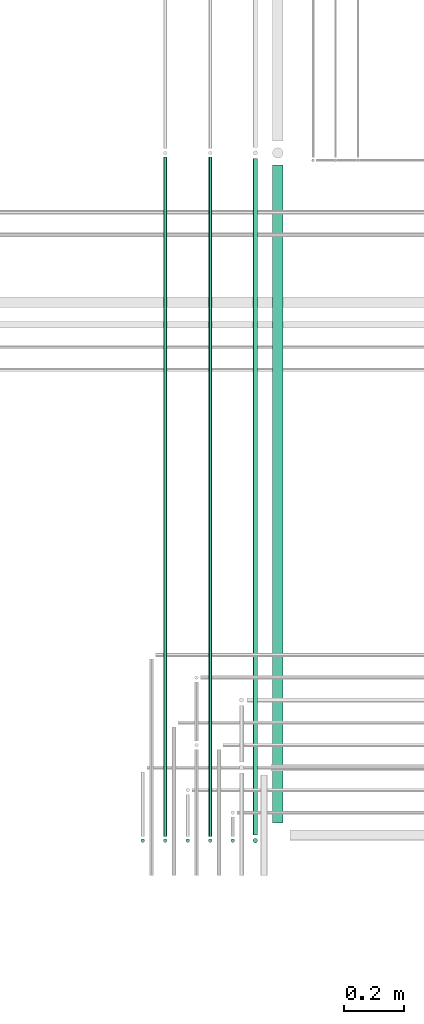
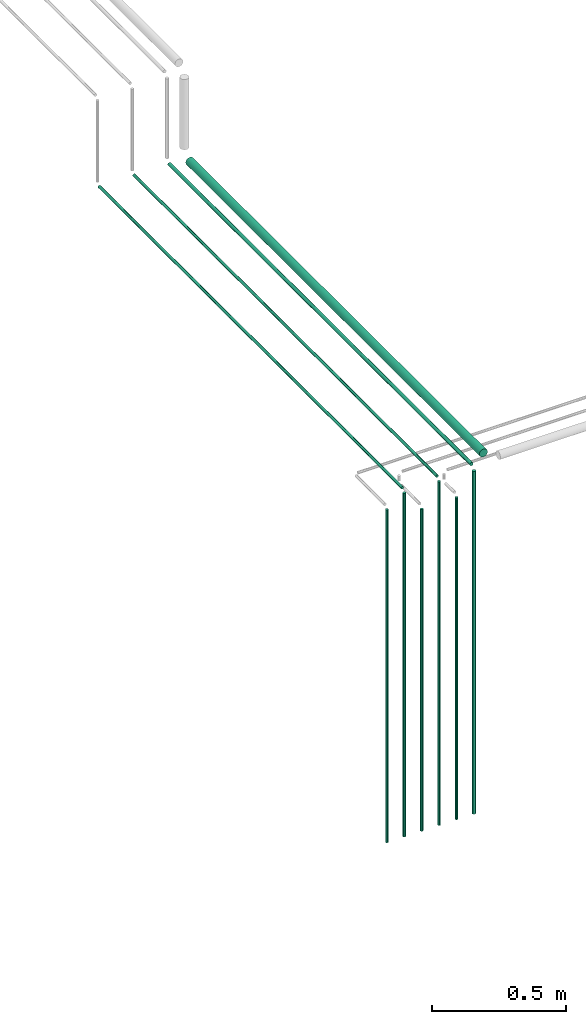
# One storey, part 109 of 331: 10 flow segments.
"""IFC2X3 building model written with IfcOpenShell, lengths in millimetres."""

from ifc_helpers import new_model, entity, si_unit, converted_unit, derived_unit, direction, frame, frame_2d, origin, origin_2d_with_axis, place, context, subcontext, project, spatial, circle, extrude, type_object, element, save


model = new_model("IFC2X3")

# Units and contexts
model_context = context("Model", 3, precision=0.01, world=origin(), true_north=direction((6.12303176911189e-17, 1.0)))
body_context = subcontext(model_context, "Body", "Model", "MODEL_VIEW")
ifc_project = project(units=[si_unit("LENGTHUNIT", "METRE", prefix="MILLI"), si_unit("AREAUNIT", "SQUARE_METRE"), si_unit("VOLUMEUNIT", "CUBIC_METRE"), converted_unit("PLANEANGLEUNIT", "DEGREE", entity("IfcRatioMeasure", 0.0174532925199433), si_unit("PLANEANGLEUNIT", "RADIAN"), dimensions=[0, 0, 0, 0, 0, 0, 0]), si_unit("MASSUNIT", "GRAM", prefix="KILO"), derived_unit("MASSDENSITYUNIT", [(si_unit("MASSUNIT", "GRAM", prefix="KILO"), 1), (si_unit("LENGTHUNIT", "METRE"), -3)]), derived_unit("MOMENTOFINERTIAUNIT", [(si_unit("LENGTHUNIT", "METRE"), 4)]), si_unit("TIMEUNIT", "SECOND"), si_unit("FREQUENCYUNIT", "HERTZ"), si_unit("THERMODYNAMICTEMPERATUREUNIT", "DEGREE_CELSIUS"), derived_unit("THERMALTRANSMITTANCEUNIT", [(si_unit("MASSUNIT", "GRAM", prefix="KILO"), 1), (si_unit("THERMODYNAMICTEMPERATUREUNIT", "KELVIN"), -1), (si_unit("TIMEUNIT", "SECOND"), -3)]), derived_unit("VOLUMETRICFLOWRATEUNIT", [(si_unit("LENGTHUNIT", "METRE"), 3), (si_unit("TIMEUNIT", "SECOND"), -1)]), derived_unit("MASSFLOWRATEUNIT", [(si_unit("MASSUNIT", "GRAM", prefix="KILO"), 1), (si_unit("TIMEUNIT", "SECOND"), -1)]), derived_unit("ROTATIONALFREQUENCYUNIT", [(si_unit("TIMEUNIT", "SECOND"), -1)]), si_unit("ELECTRICCURRENTUNIT", "AMPERE"), si_unit("ELECTRICVOLTAGEUNIT", "VOLT"), si_unit("POWERUNIT", "WATT"), si_unit("FORCEUNIT", "NEWTON", prefix="KILO"), si_unit("ILLUMINANCEUNIT", "LUX"), si_unit("LUMINOUSFLUXUNIT", "LUMEN"), si_unit("LUMINOUSINTENSITYUNIT", "CANDELA"), derived_unit("USERDEFINED", [(si_unit("MASSUNIT", "GRAM", prefix="KILO"), -1), (si_unit("LENGTHUNIT", "METRE"), -2), (si_unit("TIMEUNIT", "SECOND"), 3), (si_unit("LUMINOUSFLUXUNIT", "LUMEN"), 1)]), derived_unit("LINEARVELOCITYUNIT", [(si_unit("LENGTHUNIT", "METRE"), 1), (si_unit("TIMEUNIT", "SECOND"), -1)]), si_unit("PRESSUREUNIT", "PASCAL"), derived_unit("USERDEFINED", [(si_unit("LENGTHUNIT", "METRE"), -2), (si_unit("MASSUNIT", "GRAM", prefix="KILO"), 1), (si_unit("TIMEUNIT", "SECOND"), -2)]), derived_unit("LINEARFORCEUNIT", [(si_unit("MASSUNIT", "GRAM", prefix="KILO"), 1), (si_unit("LENGTHUNIT", "METRE"), 1), (si_unit("TIMEUNIT", "SECOND"), -2), (si_unit("LENGTHUNIT", "METRE"), -1)]), derived_unit("PLANARFORCEUNIT", [(si_unit("MASSUNIT", "GRAM", prefix="KILO"), 1), (si_unit("LENGTHUNIT", "METRE"), 1), (si_unit("TIMEUNIT", "SECOND"), -2), (si_unit("LENGTHUNIT", "METRE"), -2)])], contexts=[model_context])

# Site, building, storey
site_placement = place(None, frame((0.0, -0.00077364408347762, 0.0)))
site = spatial("IfcSite", under=ifc_project, at=site_placement, CompositionType="ELEMENT")
building_placement = place(site_placement, origin())
building = spatial("IfcBuilding", under=site, at=building_placement, CompositionType="ELEMENT")
storey_placement = place(building_placement, origin())
storey = spatial("IfcBuildingStorey", under=building, at=storey_placement, CompositionType="ELEMENT", Elevation=0.0)

# Flow segments
pipe_segment_type = type_object("IfcPipeSegmentType", PredefinedType="NOTDEFINED")
flow_segment_1_placement = place(storey_placement, frame((59308.2529497117, 14024.0252915914, 13170.0)))
element("IfcFlowSegment", 1, at=flow_segment_1_placement, inside=storey, type_object=pipe_segment_type, context=body_context, shape_type="SweptSolid", body=[
    extrude(circle(Radius=6.0, at=origin_2d_with_axis()), frame((7.59527223591454, 7.5952722359167, 0.0)), (0.0, 0.0, 1.0), 1516.0),
])
flow_segment_2_placement = place(storey_placement, frame((59383.2529497117, 14045.6205638274, 14742.4047277641)))
element("IfcFlowSegment", 2, at=flow_segment_2_placement, inside=storey, type_object=pipe_segment_type, context=body_context, shape_type="SweptSolid", body=[
    extrude(circle(Radius=6.0, at=origin_2d_with_axis()), frame((7.59527223591454, 0.0, 7.5952722359167), z_axis=(0.0, 1.0, 0.0), x_axis=(1.0, 0.0, 0.0)), (0.0, 0.0, 1.0), 2263.44778755093),
])
flow_segment_3_placement = place(storey_placement, frame((59383.2529497117, 14024.0252915914, 13170.0)))
element("IfcFlowSegment", 3, at=flow_segment_3_placement, inside=storey, type_object=pipe_segment_type, context=body_context, shape_type="SweptSolid", body=[
    extrude(circle(Radius=6.0, at=origin_2d_with_axis()), frame((7.59527223591454, 7.5952722359167, 0.0)), (0.0, 0.0, 1.0), 1566.0),
])
for number, where in (
    (4, (59458.2529497116, 14024.0252915914, 13170.0)),
    (5, (59608.2529497117, 14024.0252915914, 13170.0)),
):
    element("IfcFlowSegment", number, at=place(storey_placement, frame(where)), inside=storey, type_object=pipe_segment_type, context=body_context, shape_type="SweptSolid", body=[
        extrude(circle(Radius=6.0, at=frame_2d((0.0, -2.16573425859679e-12), x_axis=(1.0, 0.0))), frame((7.59527223591454, 7.59527223591887, 0.0)), (0.0, 0.0, 1.0), 1466.0),
    ])
flow_segment_4_placement = place(storey_placement, frame((59533.2529497117, 14045.6205638274, 14742.4047277641)))
element("IfcFlowSegment", 6, at=flow_segment_4_placement, inside=storey, type_object=pipe_segment_type, context=body_context, shape_type="SweptSolid", body=[
    extrude(circle(Radius=6.0, at=origin_2d_with_axis()), frame((7.59527223591454, 0.0, 7.5952722359167), z_axis=(0.0, 1.0, 0.0), x_axis=(1.0, 0.0, 0.0)), (0.0, 0.0, 1.0), 2263.44778755093),
])
flow_segment_5_placement = place(storey_placement, frame((59533.2529497117, 14024.0252915914, 13170.0)))
element("IfcFlowSegment", 7, at=flow_segment_5_placement, inside=storey, type_object=pipe_segment_type, context=body_context, shape_type="SweptSolid", body=[
    extrude(circle(Radius=6.0, at=origin_2d_with_axis()), frame((7.59527223591454, 7.5952722359167, 0.0)), (0.0, 0.0, 1.0), 1566.0),
])
flow_segment_6_placement = place(storey_placement, frame((59681.7529497117, 14049.6205638274, 14740.9047277641)))
element("IfcFlowSegment", 8, at=flow_segment_6_placement, inside=storey, type_object=pipe_segment_type, context=body_context, shape_type="SweptSolid", body=[
    extrude(circle(Radius=7.5, at=origin_2d_with_axis()), frame((9.09527223591419, 0.0, 9.09527223591636), z_axis=(0.0, 1.0, 0.0), x_axis=(1.0, 0.0, 0.0)), (0.0, 0.0, 1.0), 2255.44778755093),
])
flow_segment_7_placement = place(storey_placement, frame((59681.7529497117, 14022.5252915914, 13170.0)))
element("IfcFlowSegment", 9, at=flow_segment_7_placement, inside=storey, type_object=pipe_segment_type, context=body_context, shape_type="SweptSolid", body=[
    extrude(circle(Radius=7.5, at=origin_2d_with_axis()), frame((9.09527223591419, 9.09527223591636, 0.0)), (0.0, 0.0, 1.0), 1562.0),
])
flow_segment_8_placement = place(storey_placement, frame((59746.7529497117, 14090.0, 14730.9047277641)))
element("IfcFlowSegment", 10, at=flow_segment_8_placement, inside=storey, type_object=pipe_segment_type, context=body_context, shape_type="SweptSolid", body=[
    extrude(circle(Radius=17.5, at=frame_2d((-8.66293703438714e-12, 0.0), x_axis=(1.0, 0.0))), frame((19.0952722359206, 0.0, 19.0952722359163), z_axis=(0.0, 1.0, 0.0), x_axis=(1.0, 0.0, 0.0)), (0.0, 0.0, 1.0), 2193.06835137826),
])

save(model, "model.ifc")
